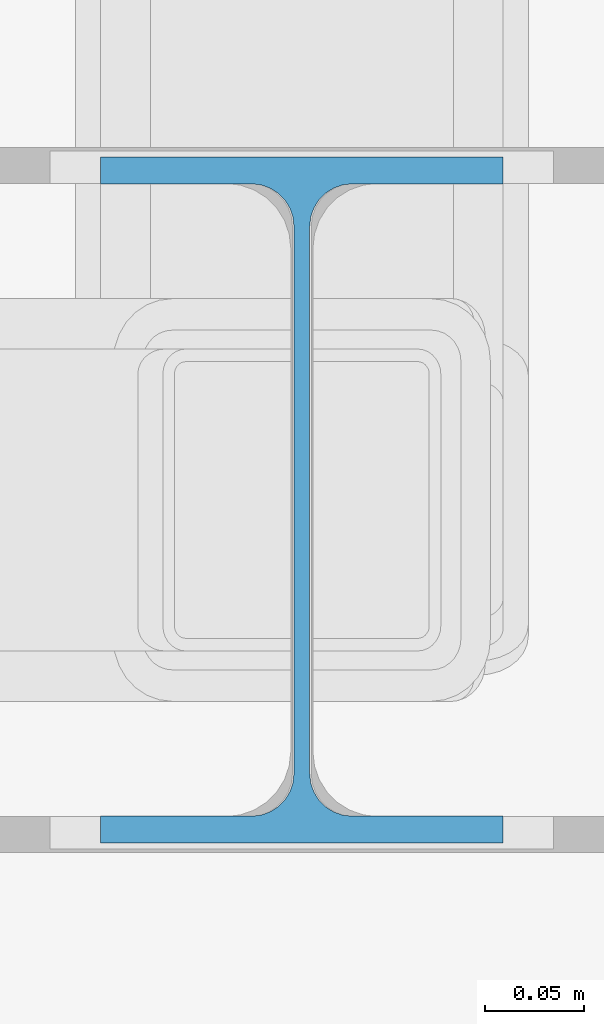
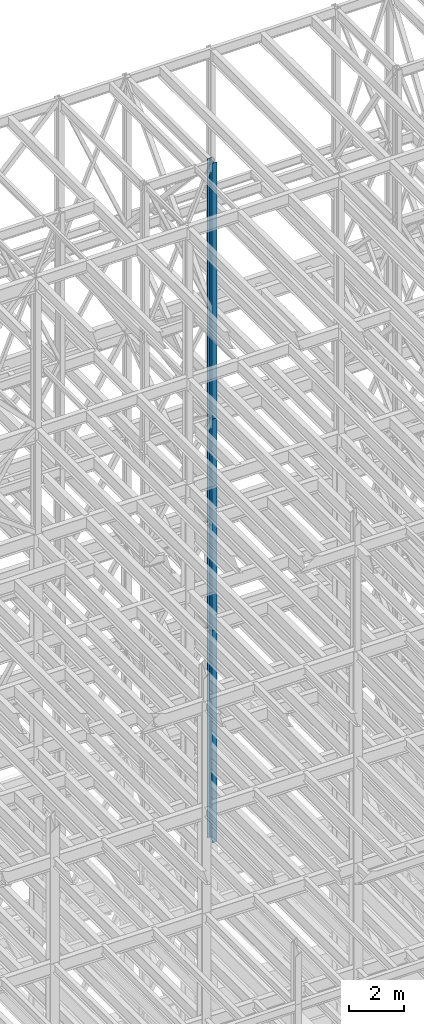
# One storey, part 94 of 150: 3 columns.
"""IFC2X3 building model written with IfcOpenShell, lengths in millimetres."""

from ifc_helpers import new_model, si_unit, frame, origin_with_axes, origin_2d_with_axis, place, context, subcontext, project, spatial, i_section, extrude, material, type_object, element, save


model = new_model("IFC2X3")

# Units and contexts
model_context = context("Model", 3, precision=1e-05, world=origin_with_axes())
body_context = subcontext(model_context, "Body", "Model", "MODEL_VIEW")
ifc_project = project(units=[si_unit("LENGTHUNIT", "METRE", prefix="MILLI"), si_unit("AREAUNIT", "SQUARE_METRE"), si_unit("VOLUMEUNIT", "CUBIC_METRE"), si_unit("MASSUNIT", "GRAM", prefix="KILO"), si_unit("TIMEUNIT", "SECOND"), si_unit("PLANEANGLEUNIT", "RADIAN"), si_unit("SOLIDANGLEUNIT", "STERADIAN"), si_unit("THERMODYNAMICTEMPERATUREUNIT", "DEGREE_CELSIUS"), si_unit("LUMINOUSINTENSITYUNIT", "LUMEN")], contexts=[model_context])

# Site, building, storey
site_placement = place(None, origin_with_axes())
site = spatial("IfcSite", under=ifc_project, at=site_placement, CompositionType="ELEMENT")
building_placement = place(site_placement, origin_with_axes())
building = spatial("IfcBuilding", under=site, at=building_placement, Name="Undefined", CompositionType="ELEMENT")
storey_placement = place(building_placement, origin_with_axes())
storey = spatial("IfcBuildingStorey", under=building, at=storey_placement, Name="Undefined", CompositionType="ELEMENT", Elevation=0.0)

# Columns
ifc_material = material(Name="STEEL/A992")
column_type = type_object("IfcColumnType", Name="W14X43", PredefinedType="NOTDEFINED")
column_placement = place(storey_placement, frame((65836.8, 25628.6, 54483.001143), z_axis=(0.0, 0.0, 1.0), x_axis=(1.0, 0.0, 0.0)))
element("IfcColumn", 1, at=column_placement, inside=storey, type_object=column_type, material=ifc_material, Name="COLUMN", ObjectType="W14X43", context=body_context, shape_type="SweptSolid", body=[
    extrude(i_section(OverallWidth=203.2, OverallDepth=346.075, WebThickness=7.9375, FlangeThickness=13.462, FilletRadius=21.4629, at=origin_2d_with_axis()), frame((0.0, 0.0, 11429.998857), z_axis=(0.0, 0.0, -1.0), x_axis=(-1.0, 0.0, 0.0)), (0.0, 0.0, 1.0), 11429.998857),
])
for number, where, z_axis, x_axis, name in (
    (2, (65836.8, 25628.6, 45034.201143), (0.0, 0.0, 1.0), (1.0, 0.0, 0.0), "COLUMN"),
    (3, (65836.8, 25628.6, 35585.401143), (0.0, 0.0, 1.0), (1.0, 0.0, 0.0), "COLUMN"),
):
    element("IfcColumn", number, at=place(storey_placement, frame(where, z_axis=z_axis, x_axis=x_axis)), inside=storey, type_object=column_type, material=ifc_material, Name=name, ObjectType="W14X43", context=body_context, shape_type="SweptSolid", body=[
        extrude(i_section(OverallWidth=203.2, OverallDepth=346.075, WebThickness=7.9375, FlangeThickness=13.462, FilletRadius=21.4629, at=origin_2d_with_axis()), frame((0.0, 0.0, 9448.8), z_axis=(0.0, 0.0, -1.0), x_axis=(-1.0, 0.0, 0.0)), (0.0, 0.0, 1.0), 9448.8),
    ])

save(model, "model.ifc")
